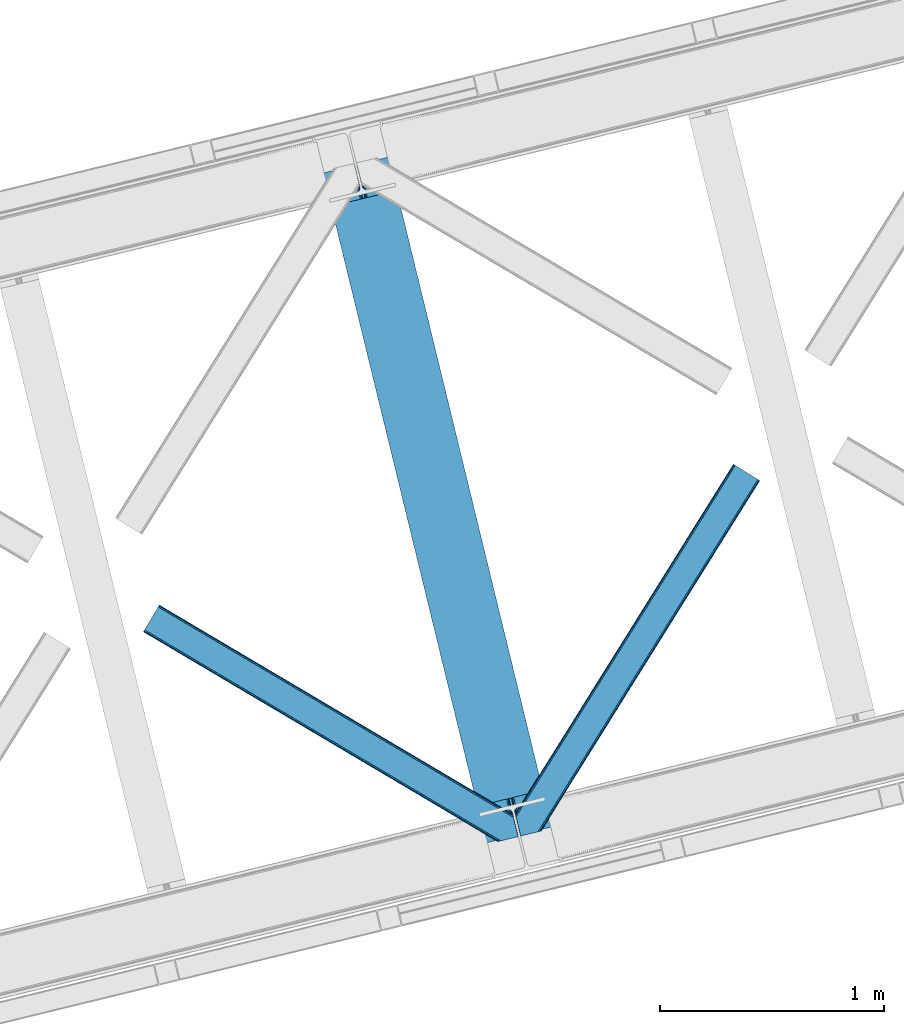
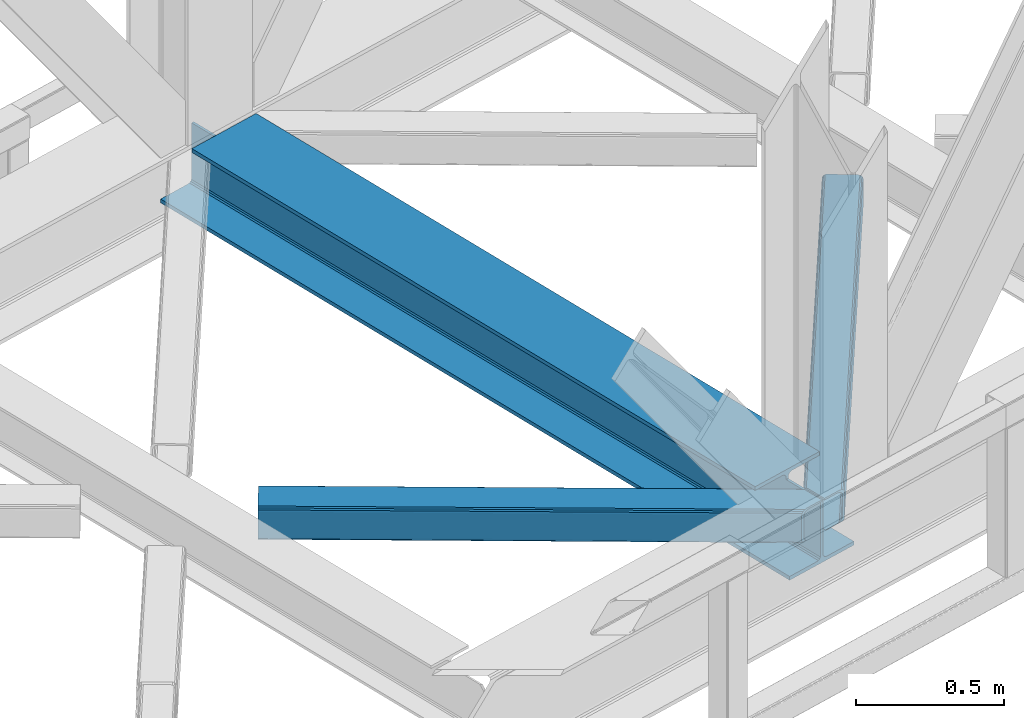
# One storey, part 61 of 93: 2 members, 1 beam.
"""IFC4 building model written with IfcOpenShell, lengths in millimetres."""

from ifc_helpers import new_model, entity, si_unit, converted_unit, derived_unit, direction, frame, origin, place, context, subcontext, project, spatial, triangles, polygons, material, type_object, element, save


model = new_model("IFC4")

# Units and contexts
model_context = context("Model", 3, precision=0.01, world=origin(), true_north=direction((6.12303176911189e-17, 1.0)))
plan_context = context("Plan", 3, precision=0.01, world=origin(), true_north=direction((6.12303176911189e-17, 1.0)))
body_context = subcontext(model_context, "Body", "Model", "MODEL_VIEW")
ifc_project = project(units=[si_unit("LENGTHUNIT", "METRE", prefix="MILLI"), si_unit("AREAUNIT", "SQUARE_METRE"), si_unit("VOLUMEUNIT", "CUBIC_METRE"), converted_unit("PLANEANGLEUNIT", "DEGREE", entity("IfcRatioMeasure", 0.0174532925199433), si_unit("PLANEANGLEUNIT", "RADIAN"), dimensions=[0, 0, 0, 0, 0, 0, 0]), si_unit("MASSUNIT", "GRAM", prefix="KILO"), derived_unit("MASSDENSITYUNIT", [(si_unit("MASSUNIT", "GRAM", prefix="KILO"), 1), (si_unit("LENGTHUNIT", "METRE"), -3)]), derived_unit("MOMENTOFINERTIAUNIT", [(si_unit("LENGTHUNIT", "METRE"), 4)]), si_unit("TIMEUNIT", "SECOND"), si_unit("FREQUENCYUNIT", "HERTZ"), si_unit("THERMODYNAMICTEMPERATUREUNIT", "DEGREE_CELSIUS"), derived_unit("THERMALTRANSMITTANCEUNIT", [(si_unit("MASSUNIT", "GRAM", prefix="KILO"), 1), (si_unit("THERMODYNAMICTEMPERATUREUNIT", "KELVIN"), -1), (si_unit("TIMEUNIT", "SECOND"), -3)]), derived_unit("VOLUMETRICFLOWRATEUNIT", [(si_unit("LENGTHUNIT", "METRE"), 3), (si_unit("TIMEUNIT", "SECOND"), -1)]), derived_unit("MASSFLOWRATEUNIT", [(si_unit("MASSUNIT", "GRAM", prefix="KILO"), 1), (si_unit("TIMEUNIT", "SECOND"), -1)]), derived_unit("ROTATIONALFREQUENCYUNIT", [(si_unit("TIMEUNIT", "SECOND"), -1)]), si_unit("ELECTRICCURRENTUNIT", "AMPERE"), si_unit("ELECTRICVOLTAGEUNIT", "VOLT"), si_unit("POWERUNIT", "WATT"), si_unit("FORCEUNIT", "NEWTON", prefix="KILO"), si_unit("ILLUMINANCEUNIT", "LUX"), si_unit("LUMINOUSFLUXUNIT", "LUMEN"), si_unit("LUMINOUSINTENSITYUNIT", "CANDELA"), derived_unit("USERDEFINED", [(si_unit("MASSUNIT", "GRAM", prefix="KILO"), -1), (si_unit("LENGTHUNIT", "METRE"), -2), (si_unit("TIMEUNIT", "SECOND"), 3), (si_unit("LUMINOUSFLUXUNIT", "LUMEN"), 1)]), derived_unit("LINEARVELOCITYUNIT", [(si_unit("LENGTHUNIT", "METRE"), 1), (si_unit("TIMEUNIT", "SECOND"), -1)]), si_unit("PRESSUREUNIT", "PASCAL"), derived_unit("USERDEFINED", [(si_unit("LENGTHUNIT", "METRE"), -2), (si_unit("MASSUNIT", "GRAM", prefix="KILO"), 1), (si_unit("TIMEUNIT", "SECOND"), -2)]), derived_unit("LINEARFORCEUNIT", [(si_unit("MASSUNIT", "GRAM", prefix="KILO"), 1), (si_unit("LENGTHUNIT", "METRE"), 1), (si_unit("TIMEUNIT", "SECOND"), -2), (si_unit("LENGTHUNIT", "METRE"), -1)]), derived_unit("PLANARFORCEUNIT", [(si_unit("MASSUNIT", "GRAM", prefix="KILO"), 1), (si_unit("LENGTHUNIT", "METRE"), 1), (si_unit("TIMEUNIT", "SECOND"), -2), (si_unit("LENGTHUNIT", "METRE"), -2)])], contexts=[model_context, plan_context])

# Site, building, storey
site_placement = place(None, origin())
site = spatial("IfcSite", under=ifc_project, at=site_placement, CompositionType="ELEMENT")
building_placement = place(site_placement, origin())
building = spatial("IfcBuilding", under=site, at=building_placement, CompositionType="ELEMENT")
storey_placement = place(building_placement, frame((0.0, 0.0, 15900.0)))
storey = spatial("IfcBuildingStorey", under=building, at=storey_placement, CompositionType="ELEMENT", Elevation=15900.0)

# Beam
ifc_material = material(Name="Metal painted (White)")
beam_type = type_object("IfcBeamType", PredefinedType="BEAM")
beam_placement = place(storey_placement, frame((-24164.8206423589, 11902.3125301785, 3385.0)))
element("IfcBeam", 1, at=beam_placement, inside=storey, type_object=beam_type, material=ifc_material, ObjectType="Steel Beam", PredefinedType="BEAM", context=body_context, shape_type="Tessellation", body=[
    polygons([(1018.69934249252, 71.0478278971021, 15.4999999999986), (1018.69934249252, 71.0478278971021, 0.0), (291.465617442446, 3054.44131043503, 0.0), (291.465617442446, 3054.44131043503, 15.4999999999986), (895.312231108556, 40.9709140873291, 15.4999999999986), (168.078506058478, 3024.36439662526, 15.4999999999986), (888.619887334602, 39.3395844888221, 16.8701684147963), (161.386162284524, 3022.73306702675, 16.8701684147963), (882.946392233978, 37.9566100336497, 20.7720779386413), (155.7126671839, 3021.35009257158, 20.7720779386413), (879.155484005407, 37.0325360459184, 26.6116982174316), (151.921758955329, 3020.42601858385, 26.6116982174316), (877.824294062006, 36.7080444135007, 33.500000000001), (150.590569011932, 3020.10152695143, 33.500000000001), (140.875048430518, 3017.73326602153, 33.500000000001), (140.875048430514, 3017.73326602153, 259.000000000002), (150.590569011932, 3020.10152695143, 259.000000000002), (0.0, 2983.39348253793, 0.0), (4.33146851719357e-12, 2983.39348253793, 15.4999999999986), (123.387111383972, 3013.4703963477, 15.4999999999986), (130.079455157931, 3015.10172594621, 16.8701684147963), (135.752950258551, 3016.48470040138, 20.7720779386413), (139.543858487122, 3017.40877438911, 26.6116982174294), (877.824294062006, 36.7080444135007, 259.000000000002), (868.108773480596, 34.3397834835992, 259.000000000002), (868.108773480596, 34.3397834835992, 33.500000000001), (866.777583537199, 34.0152918511837, 26.6116982174294), (862.986675308629, 33.0912178634502, 20.7720779386413), (857.313180208009, 31.7082434082778, 16.8701684147963), (850.62083643405, 30.076913809773, 15.4999999999986), (727.233725050078, 0.0, 15.4999999999986), (727.233725050078, 0.0, 0.0), (838.124523621651, 199.571930111228, 259.069791776412), (186.469722099967, 2872.911390143, 259.000000000002), (186.69311520182, 2871.99494573803, 259.61730333112), (186.70550404545, 2871.94412150425, 266.500003008253), (837.979344808143, 200.167408132522, 266.500002998871), (837.979694928895, 200.165971827788, 260.000004007589), (828.499586340847, 196.831858094284, 259.006343172366), (828.276216326111, 197.748309612731, 259.61730333112), (828.263827482481, 197.799133846505, 266.500003008253), (176.98998671978, 2869.57584721824, 266.500002998871), (176.989636599032, 2869.57728352297, 260.000004007589), (176.844830940692, 2870.17133233676, 259.07612046749), (176.754201518552, 2870.54312921309, 259.000000000002), (839.31083267807, 200.490677577208, 273.388305639783), (843.101109266757, 201.417342749121, 279.227924098781), (848.774180214296, 202.802057212799, 283.129832400615), (855.46637189543, 204.434010743612, 284.500000377228), (978.853400583269, 234.51126379872, 284.500000138971), (978.851730776613, 234.518113867455, 299.999995328161), (687.386308679343, 163.469484603413, 299.999995890962), (687.387978485999, 163.462634534681, 284.500000701776), (810.775007173847, 193.539887589792, 284.500000463519), (817.467494069986, 195.17063005637, 283.129832461069), (823.141405718746, 196.551895700896, 279.227924137322), (826.932940505738, 197.473399350192, 273.388305663684), (175.658498849857, 2869.25257777355, 273.388305639788), (171.868222261165, 2868.32591260164, 279.227924098781), (166.195151313635, 2866.94119813796, 283.129832400619), (159.502959632502, 2865.30924460715, 284.500000377228), (36.1159309446533, 2835.23199155204, 284.500000138971), (36.1176007513094, 2835.2251414833, 299.999995328161), (327.58302284858, 2906.27377074734, 299.999995890962), (327.581353041924, 2906.28062081608, 284.500000701776), (204.194324354084, 2876.20336776097, 284.500000463519), (197.501837457945, 2874.57262529439, 283.129832461065), (191.827925809176, 2873.19135964986, 279.227924137322), (188.036391022189, 2872.26985600057, 273.388305663684)], [[[1, 2, 3, 4]], [[5, 1, 4, 6]], [[7, 5, 6, 8]], [[9, 7, 8, 10]], [[11, 9, 10, 12]], [[13, 11, 12, 14]], [[15, 16, 17, 14, 12, 10, 8, 6, 4, 3, 18, 19, 20, 21, 22, 23]], [[13, 24, 25, 26, 27, 28, 29, 30, 31, 32, 2, 1, 5, 7, 9, 11]], [[2, 32, 18, 3]], [[32, 31, 19, 18]], [[31, 30, 20, 19]], [[27, 26, 15, 23]], [[28, 27, 23, 22]], [[29, 28, 22, 21]], [[30, 29, 21, 20]], [[33, 24, 13, 14, 17, 34, 35, 36, 37, 38]], [[25, 39, 40, 41, 42, 43, 44, 16, 15, 26]], [[39, 25, 24, 33]], [[45, 34, 17, 16]], [[41, 40, 38, 37, 46, 47, 48, 49, 50, 51, 52, 53, 54, 55, 56, 57]], [[42, 58, 59, 60, 61, 62, 63, 64, 65, 66, 67, 68, 69, 36, 35, 43]], [[46, 37, 36, 69]], [[47, 46, 69, 68]], [[48, 47, 68, 67]], [[49, 48, 67, 66]], [[50, 49, 66, 65]], [[51, 50, 65, 64]], [[52, 51, 64, 63]], [[53, 52, 63, 62]], [[54, 53, 62, 61]], [[55, 54, 61, 60]], [[56, 55, 60, 59]], [[57, 56, 59, 58]], [[41, 57, 58, 42]]], closed=False),
])

# Members
member_type_1 = type_object("IfcMemberType", PredefinedType="BRACE")
member_1_placement = place(storey_placement, frame((-23308.988873291, 11932.6995483398, 3510.00011901855)))
element("IfcMember", 2, at=member_1_placement, inside=storey, type_object=member_type_1, ObjectType="Steel Horizontal Brace", PredefinedType="BRACE", context=body_context, shape_type="Tessellation", body=[
    triangles([(986.153759765624, 1647.42967529297, 0.0), (1075.22274169922, 1591.82725524902, 0.0), (119.790362548825, 259.603921508789, 0.0), (154.551031494138, 117.003323364257, 0.0), (115.904553222656, 275.544808959961, 4.52065429687718), (117.571893310545, 268.698715209961, 1.33247680664135), (158.436840820312, 101.062435913085, 4.52065429687718), (156.767175292967, 107.908529663086, 1.33247680664135), (114.825549316403, 275.742471313477, 5.52059326172093), (115.132507324219, 275.92385559082, 5.35316162109666), (158.132208251951, 99.1218566894531, 5.27525939941552), (115.441790771481, 276.107565307617, 5.18107910156323), (158.234527587891, 99.7776306152336, 5.02062377929906), (158.190344238279, 99.4822998046875, 5.13573303222802), (115.544110107421, 276.168026733398, 5.12526855468968), (115.68596191406, 275.921530151367, 4.88574829101708), (158.336846923827, 100.433404541016, 4.76482543945531), (158.032214355466, 98.4928253173821, 5.52059326172093), (1085.71977539062, 1585.27416687012, 5.12526855468968), (1080.9037902832, 1588.28096008301, 1.33247680664135), (1088.93818359375, 1583.26498718262, 10.8028289794929), (114.21163330078, 21.8533172607422, 10.8028289794929), (109.467736816405, 20.6964111328125, 5.52059326172093), (1090.06834716797, 1582.55921630859, 17.5000946044929), (116.062683105469, 22.3044525146488, 17.5000946044929), (6.75307617187354, 102.619317626953, 5.52059326172093), (31.3655273437471, 1.65803833007885, 5.52059326172093), (1090.06834716797, 1582.55921630859, 122.500662231447), (116.062683105469, 22.3044525146488, 122.500662231447), (1088.93818359375, 1583.26498718262, 129.197927856447), (114.21163330078, 21.8533172607422, 129.197927856447), (1085.71977539062, 1585.27416687012, 134.874325561526), (108.937536621092, 20.5673492431633, 134.874325561526), (1080.9037902832, 1588.28096008301, 138.667117309571), (101.042669677732, 18.6430480957024, 138.667117309571), (1075.22274169922, 1591.82725524902, 139.999594116212), (91.7292846679666, 16.3722564697273, 139.999594116212), (980.472711181639, 1650.97597045899, 1.33247680664135), (975.656726074216, 1653.98276367187, 5.12526855468968), (1.69059448242115, 100.410150146485, 10.9621215820334), (972.438317871092, 1655.99078063965, 10.8028289794929), (971.310479736327, 1656.69655151367, 17.5000946044929), (0.239520263668965, 99.7776306152336, 12.5201660156272), (0.0, 100.760128784179, 17.5000946044929), (5.79266967773219, 76.992974853516, 139.999594116212), (986.153759765624, 1647.42967529297, 139.999594116212), (24.5612915039055, 0.0, 139.999594116212), (971.310479736327, 1656.69655151367, 122.500662231447), (0.0, 100.760128784179, 122.500662231447), (980.472711181639, 1650.97597045899, 138.667117309571), (3.57652587890334, 86.0889312744148, 138.667117309571), (975.656726074216, 1653.98276367187, 134.874325561526), (1.69757080078125, 93.7989257812496, 134.874325561526), (972.438317871092, 1655.99078063965, 129.197927856447), (0.44183349609375, 98.9509368896488, 129.197927856447), (29.9260803222642, 1.30689697265552, 6.99957275390625), (12.1969299316406, 74.0326904296871, 6.99957275390625), (8.99479980468459, 81.5485107421882, 8.3320495605476), (3.88813476562427, 84.8122650146488, 12.5201660156272), (1069.28356933594, 1595.53400573731, 6.99957275390625), (81.9973205566384, 14.0003082275398, 6.99957275390625), (992.092932128904, 1643.72292480469, 6.99957275390625), (981.593572998045, 1650.27485046387, 12.1260040283232), (978.379815673827, 1652.28519287109, 17.8035644531265), (2.75797119140407, 89.4445404052731, 17.8035644531265), (986.409558105468, 1647.26805725098, 8.3320495605476), (977.245001220701, 1652.98863830566, 24.4996673583992), (2.3184631347649, 91.2537322998051, 24.4996673583992), (977.245001220701, 1652.98863830566, 115.501089477541), (2.3184631347649, 91.2537322998051, 115.501089477541), (4.01370849609157, 84.2925292968757, 127.87475280762), (2.75797119140407, 89.4445404052731, 122.196029663086), (5.89498901367188, 76.5813720703118, 131.667544555665), (8.11113281249709, 67.4865783691403, 133.000021362306), (24.5612915039055, 0.0, 133.000021362306), (978.379815673827, 1652.28519287109, 122.196029663086), (981.593572998045, 1650.27485046387, 127.87475280762), (986.409558105468, 1647.26805725098, 131.667544555665), (992.092932128904, 1643.72292480469, 133.000021362306), (1069.28356933594, 1595.53400573731, 133.000021362306), (81.9973205566384, 14.0003082275398, 133.000021362306), (1079.78060302734, 1588.9809173584, 12.1260040283232), (1082.99901123047, 1586.9717376709, 17.8035644531265), (1084.12917480469, 1586.26596679687, 24.4996673583992), (1074.96461791992, 1591.98654785156, 8.3320495605476), (1079.78060302734, 1588.9809173584, 127.87475280762), (1084.12917480469, 1586.26596679687, 115.501089477541), (1082.99901123047, 1586.9717376709, 122.196029663086), (1074.96461791992, 1591.98654785156, 131.667544555665), (91.3107055664041, 16.2699371337894, 131.667544555665), (99.2032470703125, 18.1942382812504, 127.87475280762), (104.479669189452, 19.4802062988274, 122.196029663086), (106.330718994141, 19.931341552734, 115.501089477541), (91.3107055664041, 16.2699371337894, 8.3320495605476), (104.479669189452, 19.4802062988274, 17.8035644531265), (99.2032470703125, 18.1942382812504, 12.1260040283232), (106.330718994141, 19.931341552734, 24.4996673583992)], [[1, 2, 3], [4, 3, 2], [5, 3, 4], [3, 5, 6], [4, 7, 5], [7, 4, 8], [9, 10, 11], [10, 12, 13], [13, 14, 10], [12, 15, 16], [16, 17, 12], [16, 5, 7], [7, 17, 16], [17, 13, 12], [14, 11, 10], [11, 18, 9], [19, 14, 13], [13, 20, 19], [13, 17, 20], [17, 7, 20], [7, 8, 20], [21, 22, 18], [18, 19, 21], [14, 19, 11], [18, 11, 19], [22, 23, 18], [21, 24, 25], [25, 22, 21], [2, 20, 4], [8, 4, 20], [23, 26, 18], [23, 27, 26], [9, 18, 26], [24, 28, 29], [29, 25, 24], [28, 30, 29], [31, 29, 30], [30, 32, 31], [33, 31, 32], [32, 34, 33], [35, 33, 34], [34, 36, 35], [37, 35, 36], [38, 6, 5], [5, 39, 38], [5, 15, 39], [40, 41, 9], [41, 39, 15], [42, 41, 40], [40, 43, 42], [43, 44, 42], [9, 26, 40], [38, 1, 6], [3, 6, 1], [36, 45, 37], [36, 46, 45], [45, 47, 37], [48, 42, 44], [44, 49, 48], [46, 50, 51], [51, 45, 46], [50, 52, 53], [53, 51, 50], [52, 54, 55], [55, 53, 52], [54, 48, 49], [49, 55, 54], [27, 56, 57], [26, 57, 58], [57, 26, 27], [59, 40, 26], [26, 58, 59], [43, 40, 59], [60, 57, 61], [60, 62, 57], [57, 56, 61], [63, 64, 65], [65, 59, 63], [66, 63, 59], [62, 66, 58], [58, 57, 62], [59, 58, 66], [64, 67, 68], [68, 65, 64], [67, 69, 70], [70, 68, 67], [71, 53, 72], [73, 74, 45], [74, 47, 45], [74, 75, 47], [51, 73, 45], [71, 51, 53], [71, 73, 51], [49, 68, 70], [55, 72, 53], [70, 72, 49], [72, 55, 49], [44, 68, 49], [43, 59, 65], [65, 68, 44], [44, 43, 65], [69, 76, 70], [72, 70, 76], [76, 77, 72], [71, 72, 77], [77, 78, 71], [73, 71, 78], [78, 79, 73], [74, 73, 79], [80, 74, 79], [74, 80, 81], [75, 74, 81], [21, 82, 83], [84, 28, 24], [21, 83, 24], [21, 19, 82], [83, 84, 24], [82, 19, 20], [60, 2, 1], [2, 85, 20], [85, 2, 60], [85, 82, 20], [30, 86, 32], [87, 28, 84], [28, 88, 30], [88, 28, 87], [30, 88, 86], [36, 80, 46], [34, 32, 86], [86, 89, 34], [89, 80, 36], [36, 34, 89], [63, 38, 39], [1, 62, 60], [1, 66, 62], [66, 1, 38], [63, 66, 38], [67, 42, 48], [41, 64, 63], [39, 41, 63], [64, 41, 42], [67, 64, 42], [50, 77, 52], [46, 80, 79], [79, 78, 46], [78, 77, 50], [50, 46, 78], [54, 52, 77], [48, 69, 67], [76, 48, 54], [48, 76, 69], [76, 54, 77], [35, 37, 90], [47, 81, 37], [81, 47, 75], [81, 90, 37], [91, 35, 90], [91, 33, 35], [33, 92, 31], [92, 33, 91], [29, 92, 93], [92, 29, 31], [61, 23, 94], [95, 96, 23], [96, 94, 23], [61, 27, 23], [27, 61, 56], [97, 95, 25], [22, 25, 95], [29, 97, 25], [97, 29, 93], [95, 23, 22], [80, 89, 90], [90, 81, 80], [89, 86, 91], [91, 90, 89], [86, 88, 92], [92, 91, 86], [88, 87, 93], [93, 92, 88], [87, 84, 93], [97, 93, 84], [84, 83, 97], [95, 97, 83], [83, 82, 95], [96, 95, 82], [82, 85, 96], [94, 96, 85], [85, 60, 94], [61, 94, 60]]),
])
member_type_2 = type_object("IfcMemberType", PredefinedType="BRACE")
member_2_placement = place(storey_placement, frame((-24965.5924072266, 11907.5534088135, 3510.00011901855)))
element("IfcMember", 3, at=member_2_placement, inside=storey, type_object=member_type_2, ObjectType="Steel Horizontal Brace", PredefinedType="BRACE", context=body_context, shape_type="Tessellation", body=[
    triangles([(1465.49659423828, 208.965151977538, 0.0), (1500.25726318359, 66.3657165527347, 0.0), (8.91340942382885, 949.276940917969, 0.0), (62.4054931640603, 1039.62956542969, 0.0), (0.676702880857192, 935.363836669922, 10.8028289794929), (1580.23145141601, 0.541827392577034, 10.8679412841811), (1578.00600585937, 0.0, 17.5000946044929), (1506.61734008789, 44.5007720947269, 9.52034912109593), (2.60914306640552, 938.628753662109, 5.12526855468968), (1504.3546875, 49.5597656249993, 5.12526855468968), (1505.23137817383, 45.9657989501957, 8.52041015625218), (1505.92435913086, 45.2332855224613, 9.02037963867406), (1506.28247680664, 44.8554016113285, 9.27850341796875), (1505.56624145508, 45.6123321533196, 8.76225585937573), (1580.68258666992, 0.652285766600471, 9.52034912109593), (1502.47573242187, 57.2697601318359, 1.33247680664135), (5.50198974609157, 943.514501953125, 1.33247680664135), (0.0, 934.218557739257, 17.5000946044929), (1578.00600585937, 0.0, 122.500662231447), (0.0, 934.218557739257, 122.500662231447), (1593.02601928711, 3.66140441894458, 138.667117309571), (1602.33940429688, 5.93103332519422, 139.999594116212), (8.91340942382885, 949.276940917969, 139.999594116212), (5.50198974609157, 943.514501953125, 138.667117309571), (1585.13115234375, 1.73710327148365, 134.874325561526), (2.60914306640552, 938.628753662109, 134.874325561526), (1579.85938110351, 0.451135253906614, 129.197927856447), (0.676702880857192, 935.363836669922, 129.197927856447), (1500.3014465332, 66.183169555663, 8.52041015625218), (1500.65956420899, 65.0402160644535, 8.90294494629052), (1501.15023193359, 64.3216552734375, 9.10758361816625), (1501.64787597656, 63.5914672851559, 9.31571044922021), (1502.13854370117, 62.8729064941399, 9.52034912109593), (1599.49306640625, 5.23688964843677, 9.52034912109593), (9.06688842773292, 949.537390136718, 8.3320495605476), (1500.15029296875, 66.8063873291012, 8.42274169922166), (6.1786926269524, 944.652804565429, 12.1260040283232), (1594.86544189453, 4.10905151367115, 12.1260040283232), (1497.94112548828, 75.8721130371086, 6.99957275390625), (12.4806335449211, 955.300991821288, 6.99957275390625), (1589.59134521484, 2.82424621581958, 17.8035644531265), (4.24392700195313, 941.387887573243, 17.8035644531265), (1587.74029541016, 2.3719482421875, 24.4996673583992), (3.56489868164135, 940.241445922851, 24.4996673583992), (1467.81505737305, 199.458755493164, 6.99957275390625), (58.8405944824226, 1033.60667724609, 6.99957275390625), (1460.5248046875, 229.365069580077, 8.52041015625218), (1465.45241088867, 209.14769897461, 8.52041015625218), (1461.40149536133, 225.771102905273, 5.12526855468968), (1465.60588989258, 208.524481201172, 8.42274169922166), (1463.28045043945, 218.061108398437, 1.33247680664135), (1587.74029541016, 2.3719482421875, 115.501089477541), (3.56489868164135, 940.241445922851, 115.501089477541), (1589.59134521484, 2.82424621581958, 122.196029663086), (4.24392700195313, 941.387887573243, 122.196029663086), (1594.86544189453, 4.10905151367115, 127.87475280762), (6.1786926269524, 944.652804565429, 127.87475280762), (1602.76030883789, 6.03451538085938, 131.667544555665), (9.06688842773292, 949.537390136718, 131.667544555665), (1612.0713684082, 8.30298156738172, 133.000021362306), (12.4806335449211, 955.300991821288, 133.000021362306), (1669.50739746094, 22.3044525146488, 139.999594116212), (1669.50739746094, 22.3044525146488, 133.000021362306), (1650.73877563476, 99.297427368163, 139.999594116212), (62.4054931640603, 1039.62956542969, 139.999594116212), (1653.05723876953, 89.7910308837891, 133.000021362306), (58.8405944824226, 1033.60667724609, 133.000021362306), (1645.38793945313, 121.255389404296, 129.197927856447), (1644.94610595703, 123.064581298828, 122.500662231447), (70.642199707032, 1053.54266967773, 129.197927856447), (71.3212280273438, 1054.68911132813, 122.500662231447), (1646.64367675781, 116.103378295898, 134.874325561526), (68.7097595214836, 1050.27891540527, 134.874325561526), (1648.52263183594, 108.393383789062, 138.667117309571), (65.8192382812485, 1045.39316711426, 138.667117309571), (1644.94610595703, 123.064581298828, 17.5000946044929), (71.3212280273438, 1054.68911132813, 17.5000946044929), (70.642199707032, 1053.54266967773, 10.8028289794929), (65.1425354003914, 1044.25486450195, 12.1260040283232), (67.0773010253906, 1047.51861877441, 17.8035644531265), (67.7540039062478, 1048.6650604248, 24.4996673583992), (68.7097595214836, 1050.27891540527, 5.12526855468968), (65.8192382812485, 1045.39316711426, 1.33247680664135), (62.2496887207017, 1039.36911621094, 8.3320495605476), (65.1425354003914, 1044.25486450195, 127.87475280762), (67.7540039062478, 1048.6650604248, 115.501089477541), (67.0773010253906, 1047.51861877441, 122.196029663086), (62.2496887207017, 1039.36911621094, 131.667544555665), (1647.26224365234, 113.558184814452, 24.4996673583992), (1647.26224365234, 113.558184814452, 115.501089477541), (1650.83876953125, 98.8858245849606, 131.667544555665), (1648.95981445312, 106.596981811523, 127.87475280762), (1647.70407714844, 111.748992919922, 122.196029663086), (1647.79244384765, 111.385061645507, 17.8686767578147), (1647.90173950195, 110.943228149414, 16.5199218750022), (1644.95540771484, 123.027374267578, 16.5199218750022), (1638.66509399414, 124.970278930663, 10.8702667236357), (1460.74572143555, 229.701095581055, 9.22734375000073), (1460.63410034179, 229.532501220703, 8.87387695312646), (1461.54334716797, 229.405764770507, 9.52034912109593), (1637.16286010742, 125.435366821288, 9.52034912109593), (1643.67409057617, 109.725860595703, 12.1260040283232), (1466.02214355469, 211.033630371094, 9.52034912109593), (1641.64165649414, 107.063232421875, 9.52034912109593)], [[1, 2, 3], [3, 4, 1], [5, 6, 7], [6, 5, 8], [5, 9, 10], [10, 11, 5], [12, 13, 5], [13, 8, 5], [5, 14, 12], [5, 11, 14], [8, 15, 6], [16, 10, 9], [9, 17, 16], [2, 16, 17], [17, 3, 2], [7, 18, 5], [7, 19, 20], [20, 18, 7], [21, 22, 23], [23, 24, 21], [25, 21, 24], [24, 26, 25], [27, 25, 26], [26, 28, 27], [19, 27, 28], [28, 20, 19], [11, 29, 30], [14, 30, 31], [12, 31, 32], [13, 32, 33], [33, 8, 13], [32, 13, 12], [31, 12, 14], [30, 14, 11], [34, 15, 33], [8, 33, 15], [35, 30, 29], [32, 35, 33], [35, 32, 31], [30, 35, 31], [29, 36, 35], [37, 38, 33], [33, 35, 37], [38, 34, 33], [35, 36, 39], [39, 40, 35], [41, 38, 37], [37, 42, 41], [43, 41, 42], [42, 44, 43], [39, 45, 40], [46, 40, 45], [1, 45, 39], [47, 48, 49], [48, 50, 1], [45, 1, 50], [48, 51, 49], [48, 1, 51], [2, 1, 39], [2, 39, 36], [29, 2, 36], [11, 10, 29], [29, 16, 2], [29, 10, 16], [52, 43, 53], [44, 53, 43], [54, 52, 55], [53, 55, 52], [56, 54, 57], [55, 57, 54], [58, 56, 59], [57, 59, 56], [60, 58, 61], [59, 61, 58], [56, 58, 21], [25, 56, 21], [25, 27, 54], [56, 25, 54], [54, 27, 19], [58, 22, 21], [62, 60, 63], [62, 22, 60], [58, 60, 22], [54, 19, 52], [43, 7, 41], [19, 43, 52], [7, 6, 41], [19, 7, 43], [15, 41, 6], [38, 41, 15], [34, 38, 15], [22, 64, 23], [22, 62, 64], [65, 23, 64], [66, 60, 61], [60, 66, 63], [61, 67, 66], [68, 69, 70], [71, 70, 69], [72, 68, 73], [70, 73, 68], [74, 72, 75], [73, 75, 72], [64, 74, 65], [75, 65, 74], [69, 76, 77], [77, 71, 69], [78, 79, 80], [81, 71, 77], [78, 80, 77], [78, 82, 79], [80, 81, 77], [79, 82, 83], [46, 4, 3], [4, 84, 83], [84, 4, 46], [84, 79, 83], [70, 85, 73], [86, 71, 81], [71, 87, 70], [87, 71, 86], [70, 87, 85], [65, 67, 23], [75, 73, 85], [85, 88, 75], [88, 67, 65], [65, 75, 88], [37, 17, 9], [3, 40, 46], [3, 35, 40], [35, 3, 17], [37, 35, 17], [44, 18, 20], [5, 42, 37], [9, 5, 37], [42, 5, 18], [44, 42, 18], [24, 57, 26], [23, 67, 61], [61, 59, 23], [59, 57, 24], [24, 23, 59], [28, 26, 57], [20, 53, 44], [55, 20, 28], [20, 55, 53], [55, 28, 57], [89, 90, 81], [86, 81, 90], [91, 66, 67], [67, 88, 91], [92, 91, 88], [88, 85, 92], [93, 92, 85], [85, 87, 93], [90, 93, 87], [87, 86, 90], [92, 72, 74], [66, 91, 64], [91, 92, 74], [94, 95, 96], [63, 66, 62], [64, 62, 66], [91, 74, 64], [94, 76, 89], [69, 90, 89], [89, 76, 69], [94, 96, 76], [69, 93, 90], [93, 72, 92], [72, 93, 68], [69, 68, 93], [77, 76, 97], [76, 96, 97], [98, 99, 82], [47, 82, 99], [47, 49, 82], [78, 97, 100], [100, 82, 78], [100, 98, 82], [97, 101, 100], [51, 1, 4], [4, 83, 51], [49, 51, 83], [83, 82, 49], [97, 78, 77], [80, 79, 102], [102, 95, 80], [80, 94, 89], [46, 45, 50], [103, 102, 79], [103, 104, 102], [50, 79, 84], [50, 103, 79], [50, 84, 46], [89, 81, 80], [95, 94, 80], [96, 102, 97], [102, 96, 95], [102, 101, 97], [102, 104, 101], [101, 104, 103], [103, 100, 101]]),
])

save(model, "model.ifc")
